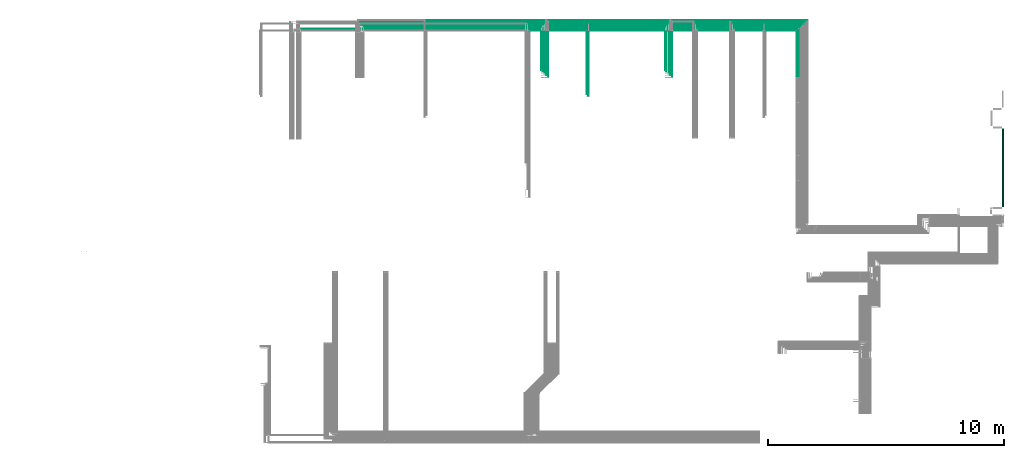
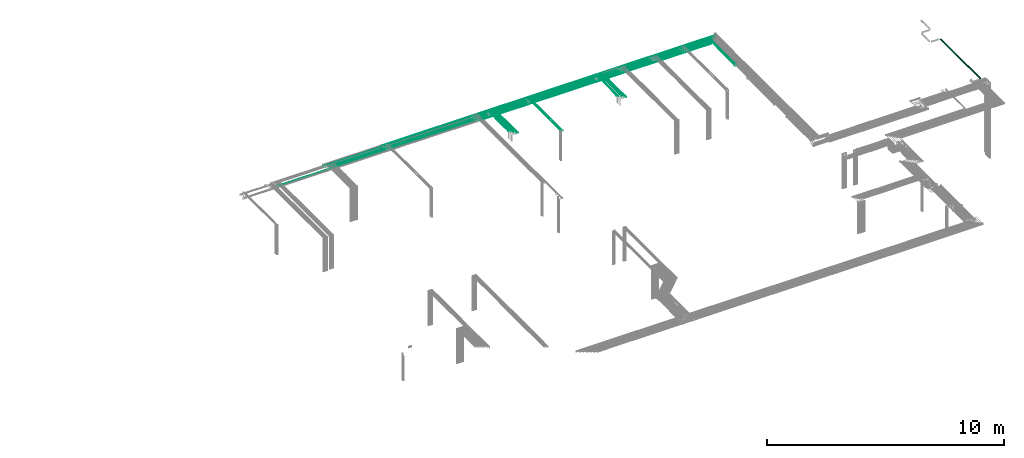
# One storey, part 36 of 89: 35 flow segments.
"""IFC2X3 building model written with IfcOpenShell, lengths in millimetres."""

from ifc_helpers import new_model, entity, si_unit, converted_unit, derived_unit, direction, frame, frame_2d, origin, origin_2d_with_axis, place, context, subcontext, project, spatial, circle, extrude, type_object, element, save


model = new_model("IFC2X3")

# Units and contexts
model_context = context("Model", 3, precision=0.01, world=origin(), true_north=direction((6.12303176911189e-17, 1.0)))
body_context = subcontext(model_context, "Body", "Model", "MODEL_VIEW")
ifc_project = project(units=[si_unit("LENGTHUNIT", "METRE", prefix="MILLI"), si_unit("AREAUNIT", "SQUARE_METRE"), si_unit("VOLUMEUNIT", "CUBIC_METRE"), converted_unit("PLANEANGLEUNIT", "DEGREE", entity("IfcRatioMeasure", 0.0174532925199433), si_unit("PLANEANGLEUNIT", "RADIAN"), dimensions=[0, 0, 0, 0, 0, 0, 0]), si_unit("MASSUNIT", "GRAM", prefix="KILO"), derived_unit("MASSDENSITYUNIT", [(si_unit("MASSUNIT", "GRAM", prefix="KILO"), 1), (si_unit("LENGTHUNIT", "METRE"), -3)]), derived_unit("MOMENTOFINERTIAUNIT", [(si_unit("LENGTHUNIT", "METRE"), 4)]), si_unit("TIMEUNIT", "SECOND"), si_unit("FREQUENCYUNIT", "HERTZ"), si_unit("THERMODYNAMICTEMPERATUREUNIT", "DEGREE_CELSIUS"), derived_unit("THERMALTRANSMITTANCEUNIT", [(si_unit("MASSUNIT", "GRAM", prefix="KILO"), 1), (si_unit("THERMODYNAMICTEMPERATUREUNIT", "KELVIN"), -1), (si_unit("TIMEUNIT", "SECOND"), -3)]), derived_unit("VOLUMETRICFLOWRATEUNIT", [(si_unit("LENGTHUNIT", "METRE"), 3), (si_unit("TIMEUNIT", "SECOND"), -1)]), derived_unit("MASSFLOWRATEUNIT", [(si_unit("MASSUNIT", "GRAM", prefix="KILO"), 1), (si_unit("TIMEUNIT", "SECOND"), -1)]), derived_unit("ROTATIONALFREQUENCYUNIT", [(si_unit("TIMEUNIT", "SECOND"), -1)]), si_unit("ELECTRICCURRENTUNIT", "AMPERE"), si_unit("ELECTRICVOLTAGEUNIT", "VOLT"), si_unit("POWERUNIT", "WATT"), si_unit("FORCEUNIT", "NEWTON", prefix="KILO"), si_unit("ILLUMINANCEUNIT", "LUX"), si_unit("LUMINOUSFLUXUNIT", "LUMEN"), si_unit("LUMINOUSINTENSITYUNIT", "CANDELA"), derived_unit("USERDEFINED", [(si_unit("MASSUNIT", "GRAM", prefix="KILO"), -1), (si_unit("LENGTHUNIT", "METRE"), -2), (si_unit("TIMEUNIT", "SECOND"), 3), (si_unit("LUMINOUSFLUXUNIT", "LUMEN"), 1)]), derived_unit("LINEARVELOCITYUNIT", [(si_unit("LENGTHUNIT", "METRE"), 1), (si_unit("TIMEUNIT", "SECOND"), -1)]), si_unit("PRESSUREUNIT", "PASCAL"), derived_unit("USERDEFINED", [(si_unit("LENGTHUNIT", "METRE"), -2), (si_unit("MASSUNIT", "GRAM", prefix="KILO"), 1), (si_unit("TIMEUNIT", "SECOND"), -2)]), derived_unit("LINEARFORCEUNIT", [(si_unit("MASSUNIT", "GRAM", prefix="KILO"), 1), (si_unit("LENGTHUNIT", "METRE"), 1), (si_unit("TIMEUNIT", "SECOND"), -2), (si_unit("LENGTHUNIT", "METRE"), -1)]), derived_unit("PLANARFORCEUNIT", [(si_unit("MASSUNIT", "GRAM", prefix="KILO"), 1), (si_unit("LENGTHUNIT", "METRE"), 1), (si_unit("TIMEUNIT", "SECOND"), -2), (si_unit("LENGTHUNIT", "METRE"), -2)])], contexts=[model_context])

# Site, building, storey
site_placement = place(None, frame((0.0, -0.00077364408347762, 0.0)))
site = spatial("IfcSite", under=ifc_project, at=site_placement, CompositionType="ELEMENT")
building_placement = place(site_placement, origin())
building = spatial("IfcBuilding", under=site, at=building_placement, CompositionType="ELEMENT")
storey_placement = place(building_placement, frame((0.0, 0.0, 24000.0)))
storey = spatial("IfcBuildingStorey", under=building, at=storey_placement, CompositionType="ELEMENT", Elevation=24000.0)

# Flow segments
pipe_segment_type = type_object("IfcPipeSegmentType", PredefinedType="NOTDEFINED")
flow_segment_1_placement = place(storey_placement, frame((73267.4868783471, 11184.9999181315, 2421.40472776407)))
element("IfcFlowSegment", 1, at=flow_segment_1_placement, inside=storey, type_object=pipe_segment_type, context=body_context, shape_type="SweptSolid", body=[
    extrude(circle(Radius=27.0, at=frame_2d((1.73258740687743e-11, 0.0), x_axis=(1.0, 0.0))), frame((28.5952722359358, 0.0, 28.5952722359141), z_axis=(0.0, 1.0, 0.0), x_axis=(-1.0, 0.0, 0.0)), (0.0, 0.0, 1.0), 3295.24742631794),
])
flow_segment_2_placement = place(storey_placement, frame((64609.4898186752, 16663.8231771437, 2844.4047277641)))
element("IfcFlowSegment", 2, at=flow_segment_2_placement, inside=storey, type_object=pipe_segment_type, context=body_context, shape_type="SweptSolid", body=[
    extrude(circle(Radius=4.0, at=frame_2d((8.66293703438714e-12, 0.0), x_axis=(1.0, 0.0))), frame((5.59527223591499, 0.0, 5.59527223591499), z_axis=(0.0, 1.0, 0.0), x_axis=(-1.0, 0.0, 0.0)), (0.0, 0.0, 1.0), 2051.17682285641),
])
flow_segment_3_placement = place(storey_placement, frame((64530.9898186752, 16664.8231771437, 2840.9047277641)))
element("IfcFlowSegment", 3, at=flow_segment_3_placement, inside=storey, type_object=pipe_segment_type, context=body_context, shape_type="SweptSolid", body=[
    extrude(circle(Radius=7.5, at=origin_2d_with_axis()), frame((9.09527223591419, 0.0, 9.09527223591419), z_axis=(0.0, 1.0, 0.0), x_axis=(-1.0, 0.0, 0.0)), (0.0, 0.0, 1.0), 1967.17682285641),
])
flow_segment_4_placement = place(storey_placement, frame((63229.2139675456, 18640.9047277641, 2765.90472776411)))
element("IfcFlowSegment", 4, at=flow_segment_4_placement, inside=storey, type_object=pipe_segment_type, context=body_context, shape_type="SweptSolid", body=[
    extrude(circle(Radius=7.5, at=origin_2d_with_axis()), frame((0.0, 9.09527223591636, 9.09527223591419), z_axis=(1.0, 0.0, 0.0), x_axis=(0.0, -1.0, 0.0)), (0.0, 0.0, 1.0), 1292.87112336553),
])
flow_segment_5_placement = place(storey_placement, frame((45849.7162014781, 19019.4047277642, 2769.40472776408)))
element("IfcFlowSegment", 5, at=flow_segment_5_placement, inside=storey, type_object=pipe_segment_type, context=body_context, shape_type="SweptSolid", body=[
    extrude(circle(Radius=4.0, at=origin_2d_with_axis()), frame((0.0, 5.59527223591499, 5.59527223591499), z_axis=(1.0, 0.0, 0.0), x_axis=(0.0, -1.0, 0.0)), (0.0, 0.0, 1.0), 13399.1009253623),
])
flow_segment_6_placement = place(storey_placement, frame((43490.3360917165, 18719.4047277642, 2769.40472776408)))
element("IfcFlowSegment", 6, at=flow_segment_6_placement, inside=storey, type_object=pipe_segment_type, context=body_context, shape_type="SweptSolid", body=[
    extrude(circle(Radius=4.0, at=origin_2d_with_axis()), frame((0.0, 5.59527223591932, 5.59527223591499), z_axis=(1.0, 0.0, 0.0), x_axis=(0.0, -1.0, 0.0)), (0.0, 0.0, 1.0), 16810.2814987434),
])
flow_segment_7_placement = place(storey_placement, frame((61726.1883857463, 19019.4047277642, 2769.40472776411)))
element("IfcFlowSegment", 7, at=flow_segment_7_placement, inside=storey, type_object=pipe_segment_type, context=body_context, shape_type="SweptSolid", body=[
    extrude(circle(Radius=4.0, at=origin_2d_with_axis()), frame((0.0, 5.59527223592365, 5.59527223591499), z_axis=(1.0, 0.0, 0.0), x_axis=(0.0, -1.0, 0.0)), (0.0, 0.0, 1.0), 3178.61130752173),
])
flow_segment_8_placement = place(storey_placement, frame((58948.2302911104, 16976.9999542306, 3069.40472812301)))
element("IfcFlowSegment", 8, at=flow_segment_8_placement, inside=storey, type_object=pipe_segment_type, context=body_context, shape_type="SweptSolid", body=[
    extrude(circle(Radius=4.0, at=origin_2d_with_axis()), frame((5.59527223573307, 3.8459999080942e-05, 5.59527223591499), z_axis=(9.61499974327806e-06, 1.0, 0.0), x_axis=(1.0, -9.61499974327806e-06, 0.0)), (0.0, 0.0, 1.0), 1656.15354405629),
])
flow_segment_9_placement = place(storey_placement, frame((58998.2462150261, 16902.0, 3069.40472776409)))
element("IfcFlowSegment", 9, at=flow_segment_9_placement, inside=storey, type_object=pipe_segment_type, context=body_context, shape_type="SweptSolid", body=[
    extrude(circle(Radius=4.0, at=origin_2d_with_axis()), frame((5.59527223591499, 0.0, 5.59527223591499), z_axis=(0.0, 1.0, 0.0), x_axis=(1.0, 0.0, 0.0)), (0.0, 0.0, 1.0), 1731.15354397928),
])
flow_segment_10_placement = place(storey_placement, frame((59098.2462150261, 16827.0, 3069.40472776409)))
element("IfcFlowSegment", 10, at=flow_segment_10_placement, inside=storey, type_object=pipe_segment_type, context=body_context, shape_type="SweptSolid", body=[
    extrude(circle(Radius=4.0, at=origin_2d_with_axis()), frame((5.59527223593232, 0.0, 5.59527223591499), z_axis=(0.0, 1.0, 0.0), x_axis=(1.0, 0.0, 0.0)), (0.0, 0.0, 1.0), 1806.15354397927),
])
flow_segment_11_placement = place(storey_placement, frame((59173.2462150261, 16752.0, 3069.40472776409)))
element("IfcFlowSegment", 11, at=flow_segment_11_placement, inside=storey, type_object=pipe_segment_type, context=body_context, shape_type="SweptSolid", body=[
    extrude(circle(Radius=4.0, at=origin_2d_with_axis()), frame((5.59527223593232, 0.0, 5.59527223591499), z_axis=(0.0, 1.0, 0.0), x_axis=(1.0, 0.0, 0.0)), (0.0, 0.0, 1.0), 1881.15354397927),
])
flow_segment_12_placement = place(storey_placement, frame((59248.2462150261, 16677.0, 3069.40472776409)))
element("IfcFlowSegment", 12, at=flow_segment_12_placement, inside=storey, type_object=pipe_segment_type, context=body_context, shape_type="SweptSolid", body=[
    extrude(circle(Radius=4.0, at=origin_2d_with_axis()), frame((5.59527223594098, 0.0, 5.59527223591499), z_axis=(0.0, 1.0, 0.0), x_axis=(1.0, 0.0, 0.0)), (0.0, 0.0, 1.0), 1956.15354397927),
])
flow_segment_13_placement = place(storey_placement, frame((58958.8171268404, 18794.4047277642, 2769.40472776408)))
element("IfcFlowSegment", 13, at=flow_segment_13_placement, inside=storey, type_object=pipe_segment_type, context=body_context, shape_type="SweptSolid", body=[
    extrude(circle(Radius=4.0, at=frame_2d((2.16573425859679e-12, 0.0), x_axis=(1.0, 0.0))), frame((0.0, 5.59527223591499, 5.59527223591499), z_axis=(1.0, 0.0, 0.0), x_axis=(0.0, 1.0, 0.0)), (0.0, 0.0, 1.0), 5721.26796407077),
])
flow_segment_14_placement = place(storey_placement, frame((59008.8171268404, 18869.4047277642, 2769.40472776408)))
element("IfcFlowSegment", 14, at=flow_segment_14_placement, inside=storey, type_object=pipe_segment_type, context=body_context, shape_type="SweptSolid", body=[
    extrude(circle(Radius=4.0, at=frame_2d((2.16573425859679e-12, 0.0), x_axis=(1.0, 0.0))), frame((0.0, 5.59527223591499, 5.59527223591499), z_axis=(1.0, 0.0, 0.0), x_axis=(0.0, 1.0, 0.0)), (0.0, 0.0, 1.0), 5745.98256642766),
])
flow_segment_15_placement = place(storey_placement, frame((59183.8171268404, 19094.4047277642, 2769.40472776408)))
element("IfcFlowSegment", 15, at=flow_segment_15_placement, inside=storey, type_object=pipe_segment_type, context=body_context, shape_type="SweptSolid", body=[
    extrude(circle(Radius=4.0, at=frame_2d((2.16573425859679e-12, 0.0), x_axis=(1.0, 0.0))), frame((0.0, 5.59527223591499, 5.59527223591499), z_axis=(1.0, 0.0, 0.0), x_axis=(0.0, 1.0, 0.0)), (0.0, 0.0, 1.0), 5795.98256642765),
])
flow_segment_16_placement = place(storey_placement, frame((55614.4556880887, 15945.0, 3069.40472776409)))
element("IfcFlowSegment", 16, at=flow_segment_16_placement, inside=storey, type_object=pipe_segment_type, context=body_context, shape_type="SweptSolid", body=[
    extrude(circle(Radius=4.0, at=frame_2d((3.46517481375486e-11, 0.0), x_axis=(1.0, 0.0))), frame((5.59527223594964, 0.0, 5.59527223591499), z_axis=(0.0, 1.0, 0.0), x_axis=(-1.0, 0.0, 0.0)), (0.0, 0.0, 1.0), 2695.000007309),
])
for number, where in (
    (17, (60310.6175904599, 18719.4047277642, 2769.40472776409)),
    (18, (60235.6175904599, 18944.4047277642, 2769.40472776408)),
):
    element("IfcFlowSegment", number, at=place(storey_placement, frame(where)), inside=storey, type_object=pipe_segment_type, context=body_context, shape_type="SweptSolid", body=[
        extrude(circle(Radius=4.0, at=origin_2d_with_axis()), frame((0.0, 5.59527223591499, 5.59527223591499), z_axis=(1.0, 0.0, 0.0), x_axis=(0.0, 1.0, 0.0)), (0.0, 0.0, 1.0), 1555.57079528639),
    ])
flow_segment_17_placement = place(storey_placement, frame((59108.8171268404, 18944.4047277642, 2769.40472776408)))
element("IfcFlowSegment", 19, at=flow_segment_17_placement, inside=storey, type_object=pipe_segment_type, context=body_context, shape_type="SweptSolid", body=[
    extrude(circle(Radius=4.0, at=frame_2d((2.16573425859679e-12, 0.0), x_axis=(1.0, 0.0))), frame((0.0, 5.59527223591499, 5.59527223591499), z_axis=(1.0, 0.0, 0.0), x_axis=(0.0, 1.0, 0.0)), (0.0, 0.0, 1.0), 1116.80046361957),
])
flow_segment_18_placement = place(storey_placement, frame((53688.0049870264, 16976.9999542306, 3069.40472812301)))
element("IfcFlowSegment", 20, at=flow_segment_18_placement, inside=storey, type_object=pipe_segment_type, context=body_context, shape_type="SweptSolid", body=[
    extrude(circle(Radius=4.0, at=origin_2d_with_axis()), frame((5.59527223573307, 3.8459999080942e-05, 5.59527223591499), z_axis=(9.61499974327806e-06, 1.0, 0.0), x_axis=(1.0, -9.61499974327806e-06, 0.0)), (0.0, 0.0, 1.0), 1656.15354405629),
])
flow_segment_19_placement = place(storey_placement, frame((53763.0209109421, 16902.0, 3069.40472776409)))
element("IfcFlowSegment", 21, at=flow_segment_19_placement, inside=storey, type_object=pipe_segment_type, context=body_context, shape_type="SweptSolid", body=[
    extrude(circle(Radius=4.0, at=origin_2d_with_axis()), frame((5.59527223592365, 0.0, 5.59527223591499), z_axis=(0.0, 1.0, 0.0), x_axis=(1.0, 0.0, 0.0)), (0.0, 0.0, 1.0), 1731.15354397928),
])
flow_segment_20_placement = place(storey_placement, frame((53838.0209109421, 16827.0, 3069.40472776409)))
element("IfcFlowSegment", 22, at=flow_segment_20_placement, inside=storey, type_object=pipe_segment_type, context=body_context, shape_type="SweptSolid", body=[
    extrude(circle(Radius=4.0, at=origin_2d_with_axis()), frame((5.59527223593232, 0.0, 5.59527223591499), z_axis=(0.0, 1.0, 0.0), x_axis=(1.0, 0.0, 0.0)), (0.0, 0.0, 1.0), 1806.15354397927),
])
flow_segment_21_placement = place(storey_placement, frame((53913.0209109421, 16752.0, 3069.40472776409)))
element("IfcFlowSegment", 23, at=flow_segment_21_placement, inside=storey, type_object=pipe_segment_type, context=body_context, shape_type="SweptSolid", body=[
    extrude(circle(Radius=4.0, at=origin_2d_with_axis()), frame((5.59527223593232, 0.0, 5.59527223591499), z_axis=(0.0, 1.0, 0.0), x_axis=(1.0, 0.0, 0.0)), (0.0, 0.0, 1.0), 1881.15354397927),
])
flow_segment_22_placement = place(storey_placement, frame((53988.0209109421, 16677.0, 3069.40472776409)))
element("IfcFlowSegment", 24, at=flow_segment_22_placement, inside=storey, type_object=pipe_segment_type, context=body_context, shape_type="SweptSolid", body=[
    extrude(circle(Radius=4.0, at=origin_2d_with_axis()), frame((5.59527223594098, 0.0, 5.59527223591499), z_axis=(0.0, 1.0, 0.0), x_axis=(1.0, 0.0, 0.0)), (0.0, 0.0, 1.0), 1956.15354397927),
])
flow_segment_23_placement = place(storey_placement, frame((53198.9046409091, 18640.9047277641, 2765.90472776411)))
element("IfcFlowSegment", 25, at=flow_segment_23_placement, inside=storey, type_object=pipe_segment_type, context=body_context, shape_type="SweptSolid", body=[
    extrude(circle(Radius=7.5, at=origin_2d_with_axis()), frame((0.0, 9.09527223592069, 9.09527223591419), z_axis=(1.0, 0.0, 0.0), x_axis=(0.0, -1.0, 0.0)), (0.0, 0.0, 1.0), 2413.14631941558),
])
flow_segment_24_placement = place(storey_placement, frame((61876.1883857463, 18719.4047277642, 2769.40472776409)))
element("IfcFlowSegment", 26, at=flow_segment_24_placement, inside=storey, type_object=pipe_segment_type, context=body_context, shape_type="SweptSolid", body=[
    extrude(circle(Radius=4.0, at=origin_2d_with_axis()), frame((0.0, 5.59527223591499, 5.59527223591499), z_axis=(1.0, 0.0, 0.0), x_axis=(0.0, -1.0, 0.0)), (0.0, 0.0, 1.0), 2728.89670516482),
])
flow_segment_25_placement = place(storey_placement, frame((61801.1883857463, 18944.4047277642, 2769.40472776407)))
element("IfcFlowSegment", 27, at=flow_segment_25_placement, inside=storey, type_object=pipe_segment_type, context=body_context, shape_type="SweptSolid", body=[
    extrude(circle(Radius=4.0, at=origin_2d_with_axis()), frame((0.0, 5.59527223591499, 5.59527223591499), z_axis=(1.0, 0.0, 0.0), x_axis=(0.0, 1.0, 0.0)), (0.0, 0.0, 1.0), 3028.6113075217),
])
flow_segment_26_placement = place(storey_placement, frame((60160.6175904599, 19019.4047277642, 2769.4047277641)))
element("IfcFlowSegment", 28, at=flow_segment_26_placement, inside=storey, type_object=pipe_segment_type, context=body_context, shape_type="SweptSolid", body=[
    extrude(circle(Radius=4.0, at=origin_2d_with_axis()), frame((0.0, 5.59527223591282, 5.59527223591499), z_axis=(1.0, 0.0, 0.0), x_axis=(0.0, -1.0, 0.0)), (0.0, 0.0, 1.0), 1555.57079528639),
])
flow_segment_27_placement = place(storey_placement, frame((55628.0509603247, 18640.9047277641, 2765.9047277641)))
element("IfcFlowSegment", 29, at=flow_segment_27_placement, inside=storey, type_object=pipe_segment_type, context=body_context, shape_type="SweptSolid", body=[
    extrude(circle(Radius=7.5, at=frame_2d((-2.16573425859679e-12, 0.0), x_axis=(1.0, 0.0))), frame((0.0, 9.09527223591419, 9.09527223591419), z_axis=(1.0, 0.0, 0.0), x_axis=(0.0, -1.0, 0.0)), (0.0, 0.0, 1.0), 7585.16300722093),
])
flow_segment_28_placement = place(storey_placement, frame((55689.4505749424, 15870.0, 3069.40472776409)))
element("IfcFlowSegment", 30, at=flow_segment_28_placement, inside=storey, type_object=pipe_segment_type, context=body_context, shape_type="SweptSolid", body=[
    extrude(circle(Radius=4.0, at=origin_2d_with_axis()), frame((5.59527223592365, 0.0, 5.59527223591499), z_axis=(0.0, 1.0, 0.0), x_axis=(1.0, 0.0, 0.0)), (0.0, 0.0, 1.0), 2763.15355942373),
])
flow_segment_29_placement = place(storey_placement, frame((53120.8139720311, 18944.4047277642, 2769.4047277641)))
element("IfcFlowSegment", 31, at=flow_segment_29_placement, inside=storey, type_object=pipe_segment_type, context=body_context, shape_type="SweptSolid", body=[
    extrude(circle(Radius=4.0, at=origin_2d_with_axis()), frame((0.0, 5.59527223591499, 5.59527223591499), z_axis=(1.0, 0.0, 0.0), x_axis=(0.0, 1.0, 0.0)), (0.0, 0.0, 1.0), 2569.23187514725),
])
flow_segment_30_placement = place(storey_placement, frame((55700.0458471783, 18944.4047277642, 2769.40472776409)))
element("IfcFlowSegment", 32, at=flow_segment_30_placement, inside=storey, type_object=pipe_segment_type, context=body_context, shape_type="SweptSolid", body=[
    extrude(circle(Radius=4.0, at=frame_2d((2.16573425859679e-12, 0.0), x_axis=(1.0, 0.0))), frame((0.0, 5.59527223591282, 5.59527223591499), z_axis=(1.0, 0.0, 0.0), x_axis=(0.0, 1.0, 0.0)), (0.0, 0.0, 1.0), 3398.77127966203),
])
flow_segment_31_placement = place(storey_placement, frame((46154.716201478, 18794.4047277642, 2769.40472776409)))
element("IfcFlowSegment", 33, at=flow_segment_31_placement, inside=storey, type_object=pipe_segment_type, context=body_context, shape_type="SweptSolid", body=[
    extrude(circle(Radius=4.0, at=origin_2d_with_axis()), frame((0.0, 5.59527223591932, 5.59527223591499), z_axis=(1.0, 0.0, 0.0), x_axis=(0.0, 1.0, 0.0)), (0.0, 0.0, 1.0), 12794.1009253623),
])
flow_segment_32_placement = place(storey_placement, frame((46079.716201478, 18869.4047277642, 2769.40472776409)))
element("IfcFlowSegment", 34, at=flow_segment_32_placement, inside=storey, type_object=pipe_segment_type, context=body_context, shape_type="SweptSolid", body=[
    extrude(circle(Radius=4.0, at=origin_2d_with_axis()), frame((0.0, 5.59527223591932, 5.59527223591499), z_axis=(1.0, 0.0, 0.0), x_axis=(0.0, 1.0, 0.0)), (0.0, 0.0, 1.0), 12919.1009253623),
])
flow_segment_33_placement = place(storey_placement, frame((48751.373019357, 19094.4047277642, 2769.40472776409)))
element("IfcFlowSegment", 35, at=flow_segment_33_placement, inside=storey, type_object=pipe_segment_type, context=body_context, shape_type="SweptSolid", body=[
    extrude(circle(Radius=4.0, at=origin_2d_with_axis()), frame((0.0, 5.59527223591499, 5.59527223591499), z_axis=(1.0, 0.0, 0.0), x_axis=(0.0, 1.0, 0.0)), (0.0, 0.0, 1.0), 10422.4441074834),
])

save(model, "model.ifc")
